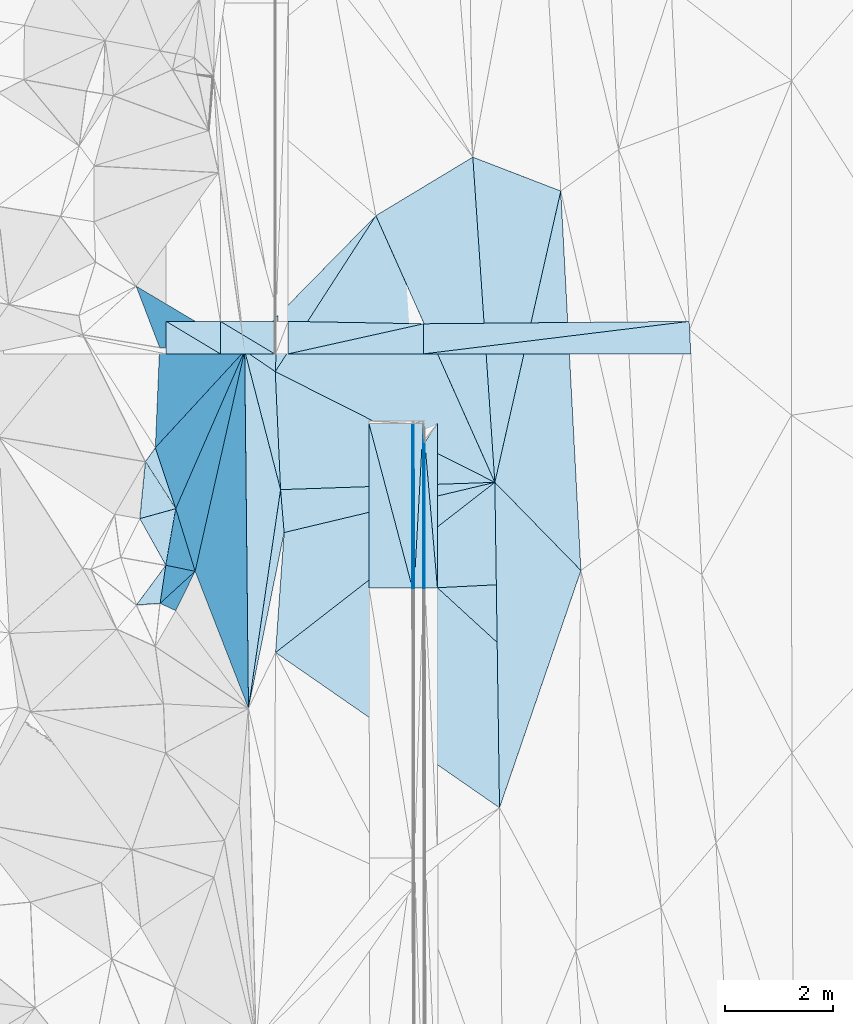
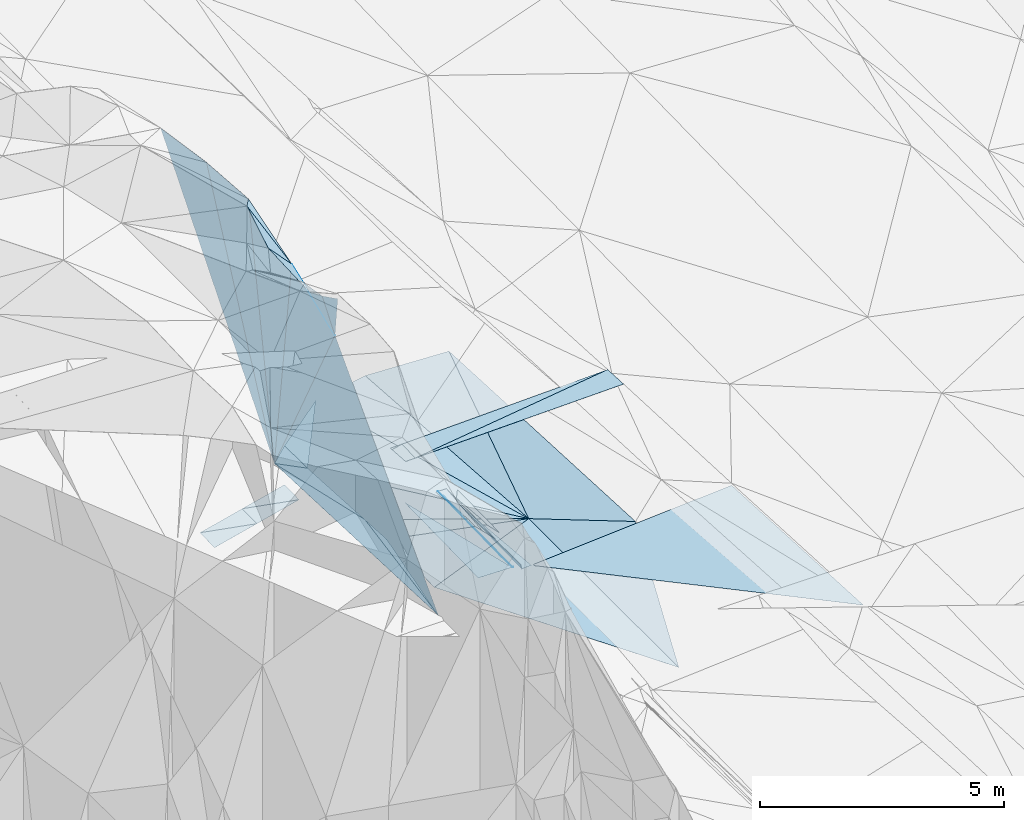
# One storey, part 83 of 275: 45 plates.
"""IFC2X3 building model written with IfcOpenShell, lengths in millimetres."""

from ifc_helpers import new_model, si_unit, frame, origin_with_axes, place, context, subcontext, project, spatial, polyline, outline, extrude, material, type_object, element, save


model = new_model("IFC2X3")

# Units and contexts
model_context = context("Model", 3, precision=1e-05, world=origin_with_axes())
body_context = subcontext(model_context, "Body", "Model", "MODEL_VIEW")
ifc_project = project(units=[si_unit("LENGTHUNIT", "METRE", prefix="MILLI"), si_unit("AREAUNIT", "SQUARE_METRE"), si_unit("VOLUMEUNIT", "CUBIC_METRE"), si_unit("MASSUNIT", "GRAM", prefix="KILO"), si_unit("TIMEUNIT", "SECOND"), si_unit("PLANEANGLEUNIT", "RADIAN"), si_unit("SOLIDANGLEUNIT", "STERADIAN"), si_unit("THERMODYNAMICTEMPERATUREUNIT", "DEGREE_CELSIUS"), si_unit("LUMINOUSINTENSITYUNIT", "LUMEN")], contexts=[model_context])

# Site, building, storey
site_placement = place(None, origin_with_axes())
site = spatial("IfcSite", under=ifc_project, at=site_placement, CompositionType="ELEMENT")
building_placement = place(site_placement, origin_with_axes())
building = spatial("IfcBuilding", under=site, at=building_placement, Name="Undefined", CompositionType="ELEMENT")
storey_placement = place(building_placement, origin_with_axes())
storey = spatial("IfcBuildingStorey", under=building, at=storey_placement, Name="Undefined", CompositionType="ELEMENT", Elevation=0.0)

# Plates
ifc_material = material()
plate_type_1 = type_object("IfcPlateType", PredefinedType="NOTDEFINED")
plate_1_placement = place(storey_placement, frame((-97377.282571069, 75504.7152635651, 43819.5137772937), z_axis=(-0.231505173660032, -0.0287121940764933, -0.972409874733876), x_axis=(-0.0106283965480763, 0.999579359783983, -0.0269840819865858)))
element("IfcPlate", 1, at=plate_1_placement, inside=storey, type_object=plate_type_1, material=ifc_material, Name="00", context=body_context, shape_type="SweptSolid", body=[
    extrude(outline(polyline([(0.0, 0.0), (6596.4814453125, 1.14596332423389e-08), (4031.74243164063, 652.562255859375), (0.0, 0.0)])), frame((-8.85201319254618e-08, 2.18876761149539e-07, -0.5000001331573), z_axis=(0.0, 0.0, 1.0), x_axis=(1.0, 0.0, 0.0)), (0.0, 0.0, 1.0), 1.0),
])
plate_type_2 = type_object("IfcPlateType", PredefinedType="NOTDEFINED")
plate_2_placement = place(storey_placement, frame((-94154.07643152, 77719.8325247116, 42614.8760524745), z_axis=(-0.970293426035433, 0.00418067990968929, -0.241894996450763), x_axis=(-0.000624968110575744, 0.999804032082094, 0.0197865319661526)))
element("IfcPlate", 2, at=plate_2_placement, inside=storey, type_object=plate_type_2, material=ifc_material, Name="00_PR", context=body_context, shape_type="SweptSolid", body=[
    extrude(outline(polyline([(0.0, 0.0), (3034.99365234375, 1.3169483281672e-08), (2685.87280273438, 123.540893554688), (0.0, 0.0)])), frame((-8.85201319254618e-08, 2.18876761149539e-07, -0.5000001331573), z_axis=(0.0, 0.0, 1.0), x_axis=(1.0, 0.0, 0.0)), (0.0, 0.0, 1.0), 1.0),
])
plate_3_placement = place(storey_placement, frame((-94125.8666505777, 80407.5694153992, 42548.1727372764), z_axis=(-0.97013630858075, 0.00416340391456981, -0.242524656150998), x_axis=(0.000665881113589022, -0.999803200403416, -0.0198271799666259)))
element("IfcPlate", 3, at=plate_3_placement, inside=storey, type_object=plate_type_2, material=ifc_material, Name="00_PR", context=body_context, shape_type="SweptSolid", body=[
    extrude(outline(polyline([(0.0, 0.0), (2688.07763671875, 2.69210431724787e-09), (2685.86669921875, 123.673461914063), (0.0, 0.0)])), frame((-8.85201319254618e-08, 2.18876761149539e-07, -0.5000001331573), z_axis=(0.0, 0.0, 1.0), x_axis=(1.0, 0.0, 0.0)), (0.0, 0.0, 1.0), 1.0),
])
plate_type_3 = type_object("IfcPlateType", PredefinedType="NOTDEFINED")
plate_4_placement = place(storey_placement, frame((-94323.6008098214, 77719.6913837399, 42614.4971970085), z_axis=(-0.0200095877071657, 0.0197694083307828, -0.999604315163775), x_axis=(-0.999799667778951, -0.000886280104156394, 0.0199959700108625)))
element("IfcPlate", 4, at=plate_4_placement, inside=storey, type_object=plate_type_3, material=ifc_material, Name="00_PR", context=body_context, shape_type="SweptSolid", body=[
    extrude(outline(polyline([(0.0, 0.0), (30.006046295166, -5.82076609134674e-11), (30.4139251708984, 3035.09545898438), (0.0, 0.0)])), frame((-8.85201319254618e-08, 2.18876761149539e-07, -0.5000001331573), z_axis=(0.0, 0.0, 1.0), x_axis=(1.0, 0.0, 0.0)), (0.0, 0.0, 1.0), 1.0),
])
plate_5_placement = place(storey_placement, frame((-94355.4977210127, 80754.1654260253, 42675.1491976148), z_axis=(-0.0199994677882401, 0.0197694185856022, -0.999604517485278), x_axis=(0.999799991070577, 0.000378680100722666, -0.0199958609880935)))
element("IfcPlate", 5, at=plate_5_placement, inside=storey, type_object=plate_type_3, material=ifc_material, Name="00_PR", context=body_context, shape_type="SweptSolid", body=[
    extrude(outline(polyline([(0.0, 0.0), (30.0062103271484, 1.89174897968769e-10), (31.9542293548584, 3035.07958984375), (0.0, 0.0)])), frame((-8.85201319254618e-08, 2.18876761149539e-07, -0.5000001331573), z_axis=(0.0, 0.0, 1.0), x_axis=(1.0, 0.0, 0.0)), (0.0, 0.0, 1.0), 1.0),
])
plate_type_4 = type_object("IfcPlateType", PredefinedType="NOTDEFINED")
plate_6_placement = place(storey_placement, frame((-99380.8598705719, 79002.5188631424, 51579.7012280975), z_axis=(-0.747756297592141, 0.289552520493882, -0.59751138674249), x_axis=(0.092249954724321, 0.936480546249964, 0.338369815953979)))
element("IfcPlate", 6, at=plate_6_placement, inside=storey, type_object=plate_type_4, material=ifc_material, Name="00", context=body_context, shape_type="SweptSolid", body=[
    extrude(outline(polyline([(0.0, 0.0), (1123.03161621094, 1.04773789644241e-09), (-17.4527587890625, 1009.79968261719), (0.0, 0.0)])), frame((-8.85201319254618e-08, 2.18876761149539e-07, -0.5000001331573), z_axis=(0.0, 0.0, 1.0), x_axis=(1.0, 0.0, 0.0)), (0.0, 0.0, 1.0), 1.0),
])
plate_type_5 = type_object("IfcPlateType", PredefinedType="NOTDEFINED")
plate_7_placement = place(storey_placement, frame((-95155.497386339, 80753.8672203649, 42691.1491969654), z_axis=(-0.0199994677882401, 0.0197694185856022, -0.999604517485278), x_axis=(0.999799990382849, 0.000372683121860294, -0.0199960080452549)))
element("IfcPlate", 7, at=plate_7_placement, inside=storey, type_object=plate_type_5, material=ifc_material, Name="00_PR", context=body_context, shape_type="SweptSolid", body=[
    extrude(outline(polyline([(0.0, 0.0), (800.159729003906, -5.76255843043327e-09), (802.126098632813, 3035.0947265625), (0.0, 0.0)])), frame((-8.85201319254618e-08, 2.18876761149539e-07, -0.5000001331573), z_axis=(0.0, 0.0, 1.0), x_axis=(1.0, 0.0, 0.0)), (0.0, 0.0, 1.0), 1.0),
])
plate_8_placement = place(storey_placement, frame((-94353.600845885, 77719.6647877863, 42615.0971969459), z_axis=(-0.0200094344994671, 0.019766780898748, -0.999604370190483), x_axis=(-0.999799675411513, -0.000876829115309103, 0.019996005044394)))
element("IfcPlate", 8, at=plate_8_placement, inside=storey, type_object=plate_type_5, material=ifc_material, Name="00_PR", context=body_context, shape_type="SweptSolid", body=[
    extrude(outline(polyline([(0.0, 0.0), (800.159851074219, -2.4156179279089e-09), (800.59619140625, 3035.49877929688), (0.0, 0.0)])), frame((-8.85201319254618e-08, 2.18876761149539e-07, -0.5000001331573), z_axis=(0.0, 0.0, 1.0), x_axis=(1.0, 0.0, 0.0)), (0.0, 0.0, 1.0), 1.0),
])
plate_type_6 = type_object("IfcPlateType", PredefinedType="NOTDEFINED")
plate_9_placement = place(storey_placement, frame((-95028.0586396697, 84589.4070167202, 42859.5298762667), z_axis=(-0.34047382320529, -0.01022036381359, -0.94019844707141), x_axis=(0.816428900931728, 0.492784786632215, -0.301009972903313)))
element("IfcPlate", 9, at=plate_9_placement, inside=storey, type_object=plate_type_6, material=ifc_material, Name="00", context=body_context, shape_type="SweptSolid", body=[
    extrude(outline(polyline([(0.0, 0.0), (2189.29614257813, -2.29920260608196e-09), (-409.283569335938, 5420.3427734375), (0.0, 0.0)])), frame((-8.85201319254618e-08, 2.18876761149539e-07, -0.5000001331573), z_axis=(0.0, 0.0, 1.0), x_axis=(1.0, 0.0, 0.0)), (0.0, 0.0, 1.0), 1.0),
])
plate_type_7 = type_object("IfcPlateType", PredefinedType="NOTDEFINED")
plate_10_placement = place(storey_placement, frame((-94125.3656123907, 80407.5772554392, 42547.7943531162), z_axis=(0.031935787106699, 0.0198383325980878, -0.999293023122649), x_axis=(0.086185780092427, -0.996133669857306, -0.0170212539631019)))
element("IfcPlate", 10, at=plate_10_placement, inside=storey, type_object=plate_type_7, material=ifc_material, Name="00_PR", context=body_context, shape_type="SweptSolid", body=[
    extrude(outline(polyline([(0.0, 0.0), (2689.34375, 1.26456143334508e-08), (2678.21923828125, 230.008071899414), (0.0, 0.0)])), frame((-8.85201319254618e-08, 2.18876761149539e-07, -0.5000001331573), z_axis=(0.0, 0.0, 1.0), x_axis=(1.0, 0.0, 0.0)), (0.0, 0.0, 1.0), 1.0),
])
plate_11_placement = place(storey_placement, frame((-93895.472368796, 80754.3368896499, 42562.0493547512), z_axis=(0.0320279137141554, 0.0198462503161241, -0.999289917437131), x_axis=(0.000624518104118216, -0.999803043715085, -0.0198364249599144)))
element("IfcPlate", 11, at=plate_11_placement, inside=storey, type_object=plate_type_7, material=ifc_material, Name="00_PR", context=body_context, shape_type="SweptSolid", body=[
    extrude(outline(polyline([(0.0, 0.0), (3026.30151367188, 1.03318598121405e-09), (346.830535888672, 230.227951049805), (0.0, 0.0)])), frame((-8.85201319254618e-08, 2.18876761149539e-07, -0.5000001331573), z_axis=(0.0, 0.0, 1.0), x_axis=(1.0, 0.0, 0.0)), (0.0, 0.0, 1.0), 1.0),
])
plate_type_8 = type_object("IfcPlateType", PredefinedType="NOTDEFINED")
plate_12_placement = place(storey_placement, frame((-94145.8957948109, 82040.8160001929, 42656.4612382612), z_axis=(0.0255602252650026, 0.0172441951021909, -0.999524543280294), x_axis=(-0.000319269067143474, 0.999851300420564, 0.0172416679752529)))
element("IfcPlate", 12, at=plate_12_placement, inside=storey, type_object=plate_type_8, material=ifc_material, Name="00_PR", context=body_context, shape_type="SweptSolid", body=[
    extrude(outline(polyline([(0.0, 0.0), (554.412719726563, 1.17870513349772e-09), (599.756042480469, 4896.15625), (0.0, 0.0)])), frame((-8.85201319254618e-08, 2.18876761149539e-07, -0.5000001331573), z_axis=(0.0, 0.0, 1.0), x_axis=(1.0, 0.0, 0.0)), (0.0, 0.0, 1.0), 1.0),
])
plate_type_9 = type_object("IfcPlateType", PredefinedType="NOTDEFINED")
plate_13_placement = place(storey_placement, frame((-96645.8061964554, 82040.2527788224, 42590.5822459599), z_axis=(0.0264281702336073, 0.0168276916030396, -0.999509069800478), x_axis=(0.975813519099114, 0.216612007085944, 0.0294485030112235)))
element("IfcPlate", 13, at=plate_13_placement, inside=storey, type_object=plate_type_9, material=ifc_material, Name="00_PR", context=body_context, shape_type="SweptSolid", body=[
    extrude(outline(polyline([(0.0, 0.0), (2561.69213867188, 1.82335497811437e-08), (2441.515625, 541.226989746094), (0.0, 0.0)])), frame((-8.85201319254618e-08, 2.18876761149539e-07, -0.5000001331573), z_axis=(0.0, 0.0, 1.0), x_axis=(1.0, 0.0, 0.0)), (0.0, 0.0, 1.0), 1.0),
])
plate_type_10 = type_object("IfcPlateType", PredefinedType="NOTDEFINED")
plate_14_placement = place(storey_placement, frame((-97895.6978779467, 82040.320835584, 42328.1019897283), z_axis=(0.242502556446776, 0.015995200320954, -0.970018898621811), x_axis=(-0.970142513980485, -0.000125957068758375, -0.242535536988791)))
element("IfcPlate", 14, at=plate_14_placement, inside=storey, type_object=plate_type_10, material=ifc_material, Name="00_PR", context=body_context, shape_type="SweptSolid", body=[
    extrude(outline(polyline([(0.0, 0.0), (1030.77673339844, -2.18278728425503e-09), (1028.33764648438, 600.075988769531), (0.0, 0.0)])), frame((-8.85201319254618e-08, 2.18876761149539e-07, -0.5000001331573), z_axis=(0.0, 0.0, 1.0), x_axis=(1.0, 0.0, 0.0)), (0.0, 0.0, 1.0), 1.0),
])
plate_15_placement = place(storey_placement, frame((-98895.7332090437, 82640.1905313673, 42087.9869896737), z_axis=(0.242503463740528, 0.0159968132833168, -0.970018645201537), x_axis=(0.970142285513665, 0.000125957070446654, 0.242536450854585)))
element("IfcPlate", 15, at=plate_15_placement, inside=storey, type_object=plate_type_10, material=ifc_material, Name="00_PR", context=body_context, shape_type="SweptSolid", body=[
    extrude(outline(polyline([(0.0, 0.0), (1030.77697753906, -6.40284270048141e-10), (1028.33764648438, 600.075988769531), (0.0, 0.0)])), frame((-8.85201319254618e-08, 2.18876761149539e-07, -0.5000001331573), z_axis=(0.0, 0.0, 1.0), x_axis=(1.0, 0.0, 0.0)), (0.0, 0.0, 1.0), 1.0),
])
plate_16_placement = place(storey_placement, frame((-96895.6977020387, 82040.4560423032, 42578.1129899788), z_axis=(0.242504475882483, 0.0159824014684644, -0.970018629728452), x_axis=(-0.839930568099244, 0.503826673958378, -0.201681242014523)))
element("IfcPlate", 16, at=plate_16_placement, inside=storey, type_object=plate_type_10, material=ifc_material, Name="00_PR", context=body_context, shape_type="SweptSolid", body=[
    extrude(outline(polyline([(0.0, 0.0), (1190.61645507813, 2.27737473323941e-09), (300.333923339844, 519.516723632813), (0.0, 0.0)])), frame((-8.85201319254618e-08, 2.18876761149539e-07, -0.5000001331573), z_axis=(0.0, 0.0, 1.0), x_axis=(1.0, 0.0, 0.0)), (0.0, 0.0, 1.0), 1.0),
])
plate_17_placement = place(storey_placement, frame((-96895.6977020387, 82040.4560423032, 42578.1129899788), z_axis=(0.242512556018831, 0.0159967761781333, -0.970016372709822), x_axis=(-0.97013999122691, -0.000131178084174322, -0.242545625016329)))
element("IfcPlate", 17, at=plate_17_placement, inside=storey, type_object=plate_type_10, material=ifc_material, Name="00_PR", context=body_context, shape_type="SweptSolid", body=[
    extrude(outline(polyline([(0.0, 0.0), (1030.779296875, -6.69388100504875e-10), (1028.33666992188, 600.075988769531), (0.0, 0.0)])), frame((-8.85201319254618e-08, 2.18876761149539e-07, -0.5000001331573), z_axis=(0.0, 0.0, 1.0), x_axis=(1.0, 0.0, 0.0)), (0.0, 0.0, 1.0), 1.0),
])
plate_type_11 = type_object("IfcPlateType", PredefinedType="NOTDEFINED")
plate_18_placement = place(storey_placement, frame((-89251.5309826842, 82639.8886423317, 42791.95725239), z_axis=(0.0252469201921091, 0.0194112825616348, -0.99949276892338), x_axis=(0.0512155250856242, -0.998523612397733, -0.0180987699688598)))
element("IfcPlate", 18, at=plate_18_placement, inside=storey, type_object=plate_type_11, material=ifc_material, Name="00_PR", context=body_context, shape_type="SweptSolid", body=[
    extrude(outline(polyline([(0.0, 0.0), (600.096008300781, 2.9831426218152e-09), (349.967742919922, 4920.31640625), (0.0, 0.0)])), frame((-8.85201319254618e-08, 2.18876761149539e-07, -0.5000001331573), z_axis=(0.0, 0.0, 1.0), x_axis=(1.0, 0.0, 0.0)), (0.0, 0.0, 1.0), 1.0),
])
plate_type_12 = type_object("IfcPlateType", PredefinedType="NOTDEFINED")
plate_19_placement = place(storey_placement, frame((-96645.8411217925, 82640.2521360822, 42600.4722423848), z_axis=(0.0265061627239476, 0.0164768598786244, -0.999512849555318), x_axis=(0.999493801746756, -0.0180350369016532, 0.0262083519850661)))
element("IfcPlate", 19, at=plate_19_placement, inside=storey, type_object=plate_type_12, material=ifc_material, Name="00_PR", context=body_context, shape_type="SweptSolid", body=[
    extrude(outline(polyline([(0.0, 0.0), (2501.03491210938, -1.19325704872608e-08), (10.5967473983765, 599.987487792969), (0.0, 0.0)])), frame((-8.85201319254618e-08, 2.18876761149539e-07, -0.5000001331573), z_axis=(0.0, 0.0, 1.0), x_axis=(1.0, 0.0, 0.0)), (0.0, 0.0, 1.0), 1.0),
])
plate_type_13 = type_object("IfcPlateType", PredefinedType="NOTDEFINED")
plate_20_placement = place(storey_placement, frame((-94155.4880672301, 80754.2393268802, 42674.5490975316), z_axis=(-1.73343280070892e-05, 0.0197865249902491, -0.99980422740071), x_axis=(0.000624968111760039, -0.999804032082208, -0.0197865319603415)))
element("IfcPlate", 20, at=plate_20_placement, inside=storey, type_object=plate_type_13, material=ifc_material, Name="00_PR", context=body_context, shape_type="SweptSolid", body=[
    extrude(outline(polyline([(0.0, 0.0), (3034.99365234375, 1.3169483281672e-08), (3035.03637695313, 169.999588012695), (0.0, 0.0)])), frame((-8.85201319254618e-08, 2.18876761149539e-07, -0.5000001331573), z_axis=(0.0, 0.0, 1.0), x_axis=(1.0, 0.0, 0.0)), (0.0, 0.0, 1.0), 1.0),
])
plate_21_placement = place(storey_placement, frame((-94323.590810139, 77719.6913893575, 42614.4970977763), z_axis=(-7.27821138362112e-06, 0.0197859672789243, -0.999804238561662), x_axis=(-0.000624968110575744, 0.999804032082094, 0.0197865319661526)))
element("IfcPlate", 21, at=plate_21_placement, inside=storey, type_object=plate_type_13, material=ifc_material, Name="00_PR", context=body_context, shape_type="SweptSolid", body=[
    extrude(outline(polyline([(0.0, 0.0), (3035.080078125, 1.19180185720325e-08), (3035.03637695313, 169.999465942383), (0.0, 0.0)])), frame((-8.85201319254618e-08, 2.18876761149539e-07, -0.5000001331573), z_axis=(0.0, 0.0, 1.0), x_axis=(1.0, 0.0, 0.0)), (0.0, 0.0, 1.0), 1.0),
])
plate_type_14 = type_object("IfcPlateType", PredefinedType="NOTDEFINED")
plate_22_placement = place(storey_placement, frame((-89018.2849450677, 77971.2436273846, 42648.669307467), z_axis=(0.0290871015744275, 0.0195888001487019, -0.999384920554004), x_axis=(0.0529665671077184, -0.998433529983144, -0.018028559959764)))
element("IfcPlate", 22, at=plate_22_placement, inside=storey, type_object=plate_type_14, material=ifc_material, Name="00_PR", context=body_context, shape_type="SweptSolid", body=[
    extrude(outline(polyline([(0.0, 0.0), (4955.1376953125, -2.9831426218152e-08), (-13.3517427444458, 4883.51611328125), (0.0, 0.0)])), frame((-8.85201319254618e-08, 2.18876761149539e-07, -0.5000001331573), z_axis=(0.0, 0.0, 1.0), x_axis=(1.0, 0.0, 0.0)), (0.0, 0.0, 1.0), 1.0),
])
plate_type_15 = type_object("IfcPlateType", PredefinedType="NOTDEFINED")
plate_23_placement = place(storey_placement, frame((-99095.1280811454, 80309.5897210175, 51919.9041689319), z_axis=(-0.981321242644546, 0.0169233200746937, -0.1916304254867), x_axis=(0.0421898807878397, 0.990805168476111, -0.128550115052977)))
element("IfcPlate", 23, at=plate_23_placement, inside=storey, type_object=plate_type_15, material=ifc_material, Name="00", context=body_context, shape_type="SweptSolid", body=[
    extrude(outline(polyline([(0.0, 0.0), (1866.97619628906, -2.82307155430317e-09), (2906.04663085938, 8123.66748046875), (0.0, 0.0)])), frame((-8.85201319254618e-08, 2.18876761149539e-07, -0.5000001331573), z_axis=(0.0, 0.0, 1.0), x_axis=(1.0, 0.0, 0.0)), (0.0, 0.0, 1.0), 1.0),
])
plate_type_16 = type_object("IfcPlateType", PredefinedType="NOTDEFINED")
plate_24_placement = place(storey_placement, frame((-96883.669983224, 81713.5202555273, 43559.5302107075), z_axis=(-0.342122258198766, -0.0154511672636236, -0.939528403974658), x_axis=(0.85097577727239, -0.429116125413057, -0.302819380829788)))
element("IfcPlate", 24, at=plate_24_placement, inside=storey, type_object=plate_type_16, material=ifc_material, Name="00", context=body_context, shape_type="SweptSolid", body=[
    extrude(outline(polyline([(0.0, 0.0), (4758.6123046875, 1.51776475831866e-08), (1017.4248046875, 1926.09631347656), (0.0, 0.0)])), frame((-8.85201319254618e-08, 2.18876761149539e-07, -0.5000001331573), z_axis=(0.0, 0.0, 1.0), x_axis=(1.0, 0.0, 0.0)), (0.0, 0.0, 1.0), 1.0),
])
plate_type_17 = type_object("IfcPlateType", PredefinedType="NOTDEFINED")
plate_25_placement = place(storey_placement, frame((-96883.5955574227, 81713.4906713038, 43559.5108304517), z_axis=(-0.193235142631104, -0.0746156174186302, -0.978311141350017), x_axis=(-0.819981762834754, 0.559826726759041, 0.119264179973144)))
element("IfcPlate", 25, at=plate_25_placement, inside=storey, type_object=plate_type_17, material=ifc_material, Name="00", context=body_context, shape_type="SweptSolid", body=[
    extrude(outline(polyline([(0.0, 0.0), (687.549255371094, -4.54747350886464e-11), (527.700378417969, 903.012939453125), (0.0, 0.0)])), frame((-8.85201319254618e-08, 2.18876761149539e-07, -0.5000001331573), z_axis=(0.0, 0.0, 1.0), x_axis=(1.0, 0.0, 0.0)), (0.0, 0.0, 1.0), 1.0),
])
plate_type_18 = type_object("IfcPlateType", PredefinedType="NOTDEFINED")
plate_26_placement = place(storey_placement, frame((-99095.1220084961, 80309.5235635622, 51919.891082521), z_axis=(-0.969146684820884, -0.115398985144266, -0.217802152258335), x_axis=(0.190936161132907, 0.207335977901551, -0.959455665801936)))
element("IfcPlate", 26, at=plate_26_placement, inside=storey, type_object=plate_type_18, material=ifc_material, Name="00", context=body_context, shape_type="SweptSolid", body=[
    extrude(outline(polyline([(0.0, 0.0), (8627.80859375, 2.01689545065165e-08), (875.116760253906, 1343.52917480469), (0.0, 0.0)])), frame((-8.85201319254618e-08, 2.18876761149539e-07, -0.5000001331573), z_axis=(0.0, 0.0, 1.0), x_axis=(1.0, 0.0, 0.0)), (0.0, 0.0, 1.0), 1.0),
])
plate_type_19 = type_object("IfcPlateType", PredefinedType="NOTDEFINED")
plate_27_placement = place(storey_placement, frame((-92833.9035644428, 79671.5462731295, 42118.5178910074), z_axis=(0.263397362445955, 0.0310370437280091, -0.964188016609385), x_axis=(-0.067616873566513, 0.997618096652692, 0.0136415409741918)))
element("IfcPlate", 27, at=plate_27_placement, inside=storey, type_object=plate_type_19, material=ifc_material, Name="00", context=body_context, shape_type="SweptSolid", body=[
    extrude(outline(polyline([(0.0, 0.0), (6011.05078125, -2.73867044597864e-08), (5284.15771484375, 1634.45556640625), (0.0, 0.0)])), frame((-8.85201319254618e-08, 2.18876761149539e-07, -0.5000001331573), z_axis=(0.0, 0.0, 1.0), x_axis=(1.0, 0.0, 0.0)), (0.0, 0.0, 1.0), 1.0),
])
plate_type_20 = type_object("IfcPlateType", PredefinedType="NOTDEFINED")
plate_28_placement = place(storey_placement, frame((-97377.3907847726, 75504.7336872797, 43819.5529863132), z_axis=(-0.448039149308804, 0.00812872499383192, -0.893976982095522), x_axis=(0.144935114356958, 0.987391130987877, -0.0636597759406691)))
element("IfcPlate", 28, at=plate_28_placement, inside=storey, type_object=plate_type_20, material=ifc_material, Name="00", context=body_context, shape_type="SweptSolid", body=[
    extrude(outline(polyline([(0.0, 0.0), (4084.21166992188, 2.23080860450864e-08), (3315.13549804688, 200.553726196289), (0.0, 0.0)])), frame((-8.85201319254618e-08, 2.18876761149539e-07, -0.5000001331573), z_axis=(0.0, 0.0, 1.0), x_axis=(1.0, 0.0, 0.0)), (0.0, 0.0, 1.0), 1.0),
])
plate_type_21 = type_object("IfcPlateType", PredefinedType="NOTDEFINED")
plate_29_placement = place(storey_placement, frame((-92747.8179915299, 73669.8529103036, 42005.5149309342), z_axis=(0.241712046609038, 0.0217326105746267, -0.970104623307034), x_axis=(-0.0143413475447169, 0.999719975483683, 0.0188227620052461)))
element("IfcPlate", 29, at=plate_29_placement, inside=storey, type_object=plate_type_21, material=ifc_material, Name="00", context=body_context, shape_type="SweptSolid", body=[
    extrude(outline(polyline([(0.0, 0.0), (6003.36962890625, 9.02218744158745e-09), (4361.67236328125, 1611.455078125), (0.0, 0.0)])), frame((-8.85201319254618e-08, 2.18876761149539e-07, -0.5000001331573), z_axis=(0.0, 0.0, 1.0), x_axis=(1.0, 0.0, 0.0)), (0.0, 0.0, 1.0), 1.0),
])
plate_type_22 = type_object("IfcPlateType", PredefinedType="NOTDEFINED")
plate_30_placement = place(storey_placement, frame((-98902.3616228428, 78142.5307332889, 50829.7910224001), z_axis=(-0.894014823102638, 0.161484294424027, -0.417923819286641), x_axis=(0.1734695318269, 0.984794010242138, 0.00943816290195812)))
element("IfcPlate", 30, at=plate_30_placement, inside=storey, type_object=plate_type_22, material=ifc_material, Name="00", context=body_context, shape_type="SweptSolid", body=[
    extrude(outline(polyline([(0.0, 0.0), (1059.52819824219, -4.9622030928731e-09), (-26.5212383270264, 1320.68041992188), (0.0, 0.0)])), frame((-8.85201319254618e-08, 2.18876761149539e-07, -0.5000001331573), z_axis=(0.0, 0.0, 1.0), x_axis=(1.0, 0.0, 0.0)), (0.0, 0.0, 1.0), 1.0),
])
plate_type_23 = type_object("IfcPlateType", PredefinedType="NOTDEFINED")
plate_31_placement = place(storey_placement, frame((-98902.2742261598, 78142.3316709754, 50829.6733644673), z_axis=(-0.719221156468952, -0.236641172272438, -0.653239530090602), x_axis=(-0.131047675948416, -0.877128196193625, 0.462030988214684)))
element("IfcPlate", 31, at=plate_31_placement, inside=storey, type_object=plate_type_23, material=ifc_material, Name="00", context=body_context, shape_type="SweptSolid", body=[
    extrude(outline(polyline([(0.0, 0.0), (800.812072753906, 4.35102265328169e-09), (1109.37390136719, 579.214660644531), (0.0, 0.0)])), frame((-8.85201319254618e-08, 2.18876761149539e-07, -0.5000001331573), z_axis=(0.0, 0.0, 1.0), x_axis=(1.0, 0.0, 0.0)), (0.0, 0.0, 1.0), 1.0),
])
plate_type_24 = type_object("IfcPlateType", PredefinedType="NOTDEFINED")
plate_32_placement = place(storey_placement, frame((-98361.4388080408, 78031.6877593741, 49629.8967173952), z_axis=(-0.974730163104533, -0.0851158059116922, -0.206534279765402), x_axis=(-0.208884061324388, 0.674979908118668, 0.707650741934708)))
element("IfcPlate", 32, at=plate_32_placement, inside=storey, type_object=plate_type_24, material=ifc_material, Name="00", context=body_context, shape_type="SweptSolid", body=[
    extrude(outline(polyline([(0.0, 0.0), (1709.88305664063, -6.18456397205591e-09), (-1683.31982421875, 7098.97705078125), (0.0, 0.0)])), frame((-8.85201319254618e-08, 2.18876761149539e-07, -0.5000001331573), z_axis=(0.0, 0.0, 1.0), x_axis=(1.0, 0.0, 0.0)), (0.0, 0.0, 1.0), 1.0),
])
plate_type_25 = type_object("IfcPlateType", PredefinedType="NOTDEFINED")
plate_33_placement = place(storey_placement, frame((-98361.1957438546, 78031.3648599, 49629.7617454449), z_axis=(-0.488601399975053, -0.730915406271878, -0.476478059113779), x_axis=(-0.211526961063876, -0.430579072849678, 0.877415526855431)))
element("IfcPlate", 33, at=plate_33_placement, inside=storey, type_object=plate_type_25, material=ifc_material, Name="00", context=body_context, shape_type="SweptSolid", body=[
    extrude(outline(polyline([(0.0, 0.0), (1686.77209472656, 1.89174897968769e-10), (1768.94079589844, 321.011352539063), (0.0, 0.0)])), frame((-8.85201319254618e-08, 2.18876761149539e-07, -0.5000001331573), z_axis=(0.0, 0.0, 1.0), x_axis=(1.0, 0.0, 0.0)), (0.0, 0.0, 1.0), 1.0),
])
plate_type_26 = type_object("IfcPlateType", PredefinedType="NOTDEFINED")
plate_34_placement = place(storey_placement, frame((-99007.3149870506, 77439.9968559717, 51199.7980399149), z_axis=(-0.911599680114052, -0.0765520052567409, -0.403888367877969), x_axis=(0.131047675927061, 0.877128196194658, -0.462030988218779)))
element("IfcPlate", 34, at=plate_34_placement, inside=storey, type_object=plate_type_26, material=ifc_material, Name="00", context=body_context, shape_type="SweptSolid", body=[
    extrude(outline(polyline([(0.0, 0.0), (800.812072753906, 4.35102265328169e-09), (1329.02587890625, 1210.73950195313), (0.0, 0.0)])), frame((-8.85201319254618e-08, 2.18876761149539e-07, -0.5000001331573), z_axis=(0.0, 0.0, 1.0), x_axis=(1.0, 0.0, 0.0)), (0.0, 0.0, 1.0), 1.0),
])
plate_type_27 = type_object("IfcPlateType", PredefinedType="NOTDEFINED")
plate_35_placement = place(storey_placement, frame((-97447.7701903998, 82098.4290068461, 43641.9196550377), z_axis=(-0.986898817345476, -0.0148305806466479, -0.160657331609185), x_axis=(0.0106283962357464, -0.999579359783143, 0.0269840821407212)))
element("IfcPlate", 35, at=plate_35_placement, inside=storey, type_object=plate_type_27, material=ifc_material, Name="00", context=body_context, shape_type="SweptSolid", body=[
    extrude(outline(polyline([(0.0, 0.0), (6596.4814453125, 1.14596332423389e-08), (4216.865234375, 5953.74609375), (0.0, 0.0)])), frame((-8.85201319254618e-08, 2.18876761149539e-07, -0.5000001331573), z_axis=(0.0, 0.0, 1.0), x_axis=(1.0, 0.0, 0.0)), (0.0, 0.0, 1.0), 1.0),
])
plate_type_28 = type_object("IfcPlateType", PredefinedType="NOTDEFINED")
plate_36_placement = place(storey_placement, frame((-99277.223427441, 80054.2622591329, 51959.6838364398), z_axis=(-0.674097162483468, 0.381831270131595, -0.63229573514411), x_axis=(0.576033862682916, 0.807589606878517, -0.126427907933344)))
element("IfcPlate", 36, at=plate_36_placement, inside=storey, type_object=plate_type_28, material=ifc_material, Name="00", context=body_context, shape_type="SweptSolid", body=[
    extrude(outline(polyline([(0.0, 0.0), (316.385833740234, -1.45519152283669e-11), (-237.684463500977, 1504.62817382813), (0.0, 0.0)])), frame((-8.85201319254618e-08, 2.18876761149539e-07, -0.5000001331573), z_axis=(0.0, 0.0, 1.0), x_axis=(1.0, 0.0, 0.0)), (0.0, 0.0, 1.0), 1.0),
])
plate_type_29 = type_object("IfcPlateType", PredefinedType="NOTDEFINED")
plate_37_placement = place(storey_placement, frame((-99450.7166045688, 83290.1729437413, 52009.9099436147), z_axis=(-0.93469463794152, -0.306459561450424, -0.180079068741995), x_axis=(0.230583547332839, -0.137211153112521, -0.963329812245493)))
element("IfcPlate", 37, at=plate_37_placement, inside=storey, type_object=plate_type_29, material=ifc_material, Name="00", context=body_context, shape_type="SweptSolid", body=[
    extrude(outline(polyline([(0.0, 0.0), (8686.537109375, 1.46683305501938e-08), (573.236511230469, 1117.13916015625), (0.0, 0.0)])), frame((-8.85201319254618e-08, 2.18876761149539e-07, -0.5000001331573), z_axis=(0.0, 0.0, 1.0), x_axis=(1.0, 0.0, 0.0)), (0.0, 0.0, 1.0), 1.0),
])
plate_type_30 = type_object("IfcPlateType", PredefinedType="NOTDEFINED")
plate_38_placement = place(storey_placement, frame((-97447.350989345, 82098.4330887626, 43641.5055234799), z_axis=(-0.148409421054246, -0.00670257147833632, -0.988903291165482), x_axis=(0.819981762828799, -0.559826726778288, -0.119264179923749)))
element("IfcPlate", 38, at=plate_38_placement, inside=storey, type_object=plate_type_30, material=ifc_material, Name="00", context=body_context, shape_type="SweptSolid", body=[
    extrude(outline(polyline([(0.0, 0.0), (687.549255371094, -4.54747350886464e-11), (1986.365234375, 1748.73583984375), (0.0, 0.0)])), frame((-8.85201319254618e-08, 2.18876761149539e-07, -0.5000001331573), z_axis=(0.0, 0.0, 1.0), x_axis=(1.0, 0.0, 0.0)), (0.0, 0.0, 1.0), 1.0),
])
plate_type_31 = type_object("IfcPlateType", PredefinedType="NOTDEFINED")
plate_39_placement = place(storey_placement, frame((-96785.3926453893, 79537.4535515633, 43559.5304287281), z_axis=(-0.343135287629557, 0.0190903691294641, -0.939091972167733), x_axis=(0.938994789750042, 0.0318655626106522, -0.342451997719069)))
element("IfcPlate", 39, at=plate_39_placement, inside=storey, type_object=plate_type_31, material=ifc_material, Name="00", context=body_context, shape_type="SweptSolid", body=[
    extrude(outline(polyline([(0.0, 0.0), (4207.88916015625, 2.71247699856758e-08), (49.9561653137207, 793.224060058594), (0.0, 0.0)])), frame((-8.85201319254618e-08, 2.18876761149539e-07, -0.5000001331573), z_axis=(0.0, 0.0, 1.0), x_axis=(1.0, 0.0, 0.0)), (0.0, 0.0, 1.0), 1.0),
])
plate_type_32 = type_object("IfcPlateType", PredefinedType="NOTDEFINED")
plate_40_placement = place(storey_placement, frame((-99380.8634306441, 79002.4436410036, 51579.6794308585), z_axis=(-0.754758363223648, 0.13909331685309, -0.641087250185781), x_axis=(0.655841283726637, 0.181685073377417, -0.732709181511764)))
element("IfcPlate", 40, at=plate_40_placement, inside=storey, type_object=plate_type_32, material=ifc_material, Name="00", context=body_context, shape_type="SweptSolid", body=[
    extrude(outline(polyline([(0.0, 0.0), (1009.95050048828, -2.99769453704357e-09), (707.163391113281, 1015.34228515625), (0.0, 0.0)])), frame((-8.85201319254618e-08, 2.18876761149539e-07, -0.5000001331573), z_axis=(0.0, 0.0, 1.0), x_axis=(1.0, 0.0, 0.0)), (0.0, 0.0, 1.0), 1.0),
])
plate_type_33 = type_object("IfcPlateType", PredefinedType="NOTDEFINED")
plate_41_placement = place(storey_placement, frame((-92834.1979327425, 79671.4997910749, 42118.5282106265), z_axis=(-0.325444601010684, -0.0619322715975983, -0.943530712487812), x_axis=(-0.754030224841596, -0.585101595610741, 0.298487089903563)))
element("IfcPlate", 41, at=plate_41_placement, inside=storey, type_object=plate_type_33, material=ifc_material, Name="00", context=body_context, shape_type="SweptSolid", body=[
    extrude(outline(polyline([(0.0, 0.0), (5363.7158203125, 2.21189111471176e-09), (3889.45458984375, 1670.25537109375), (0.0, 0.0)])), frame((-8.85201319254618e-08, 2.18876761149539e-07, -0.5000001331573), z_axis=(0.0, 0.0, 1.0), x_axis=(1.0, 0.0, 0.0)), (0.0, 0.0, 1.0), 1.0),
])
plate_type_34 = type_object("IfcPlateType", PredefinedType="NOTDEFINED")
plate_42_placement = place(storey_placement, frame((-95028.0582141697, 84589.4072308247, 42859.5297194358), z_axis=(-0.339618413213611, -0.00979147178994462, -0.940512339358956), x_axis=(0.403595426755637, -0.904725273083071, -0.136319153997877)))
element("IfcPlate", 42, at=plate_42_placement, inside=storey, type_object=plate_type_34, material=ifc_material, Name="00", context=body_context, shape_type="SweptSolid", body=[
    extrude(outline(polyline([(0.0, 0.0), (5435.77294921875, 3.10901668854058e-08), (1757.54577636719, 3019.111328125), (0.0, 0.0)])), frame((-8.85201319254618e-08, 2.18876761149539e-07, -0.5000001331573), z_axis=(0.0, 0.0, 1.0), x_axis=(1.0, 0.0, 0.0)), (0.0, 0.0, 1.0), 1.0),
])
plate_type_35 = type_object("IfcPlateType", PredefinedType="NOTDEFINED")
plate_43_placement = place(storey_placement, frame((-91246.8630902343, 78045.3977329781, 42477.5165608634), z_axis=(0.253141997457825, 0.0336072716976412, -0.966845220504349), x_axis=(-0.689892162419726, 0.706890854705426, -0.156058078181383)))
element("IfcPlate", 43, at=plate_43_placement, inside=storey, type_object=plate_type_35, material=ifc_material, Name="00", context=body_context, shape_type="SweptSolid", body=[
    extrude(outline(polyline([(0.0, 0.0), (2300.42553710938, 8.70568328537047e-09), (5180.60888671875, 4722.10888671875), (0.0, 0.0)])), frame((-8.85201319254618e-08, 2.18876761149539e-07, -0.5000001331573), z_axis=(0.0, 0.0, 1.0), x_axis=(1.0, 0.0, 0.0)), (0.0, 0.0, 1.0), 1.0),
])
plate_type_36 = type_object("IfcPlateType", PredefinedType="NOTDEFINED")
plate_44_placement = place(storey_placement, frame((-96878.6273120248, 76533.2179511573, 43719.5367373084), z_axis=(-0.376108523994938, 0.0120487082950018, -0.926497278359074), x_axis=(0.754030224813273, 0.585101595629378, -0.298487089938578)))
element("IfcPlate", 44, at=plate_44_placement, inside=storey, type_object=plate_type_36, material=ifc_material, Name="00", context=body_context, shape_type="SweptSolid", body=[
    extrude(outline(polyline([(0.0, 0.0), (5363.7158203125, 2.21189111471176e-09), (1950.76672363281, 4938.8486328125), (0.0, 0.0)])), frame((-8.85201319254618e-08, 2.18876761149539e-07, -0.5000001331573), z_axis=(0.0, 0.0, 1.0), x_axis=(1.0, 0.0, 0.0)), (0.0, 0.0, 1.0), 1.0),
])
plate_type_37 = type_object("IfcPlateType", PredefinedType="NOTDEFINED")
plate_45_placement = place(storey_placement, frame((-96883.6264570576, 81713.4928715704, 43559.5177856446), z_axis=(-0.254975825846461, -0.0702185109493767, -0.964394467504852), x_axis=(0.051463799451265, 0.994960692009558, -0.0860505589865777)))
element("IfcPlate", 45, at=plate_45_placement, inside=storey, type_object=plate_type_37, material=ifc_material, Name="00", context=body_context, shape_type="SweptSolid", body=[
    extrude(outline(polyline([(0.0, 0.0), (1045.89672851563, -2.88127921521664e-09), (3017.12377929688, 1760.95532226563), (0.0, 0.0)])), frame((-8.85201319254618e-08, 2.18876761149539e-07, -0.5000001331573), z_axis=(0.0, 0.0, 1.0), x_axis=(1.0, 0.0, 0.0)), (0.0, 0.0, 1.0), 1.0),
])

save(model, "model.ifc")
